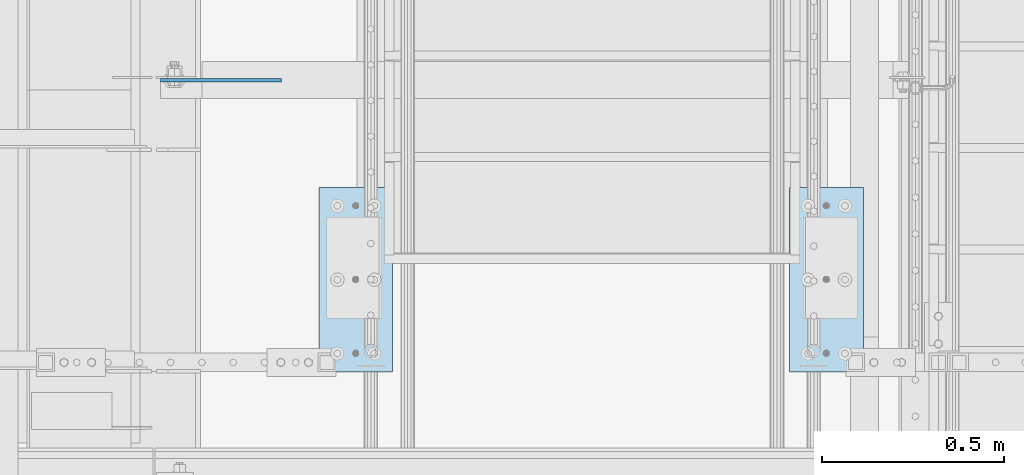
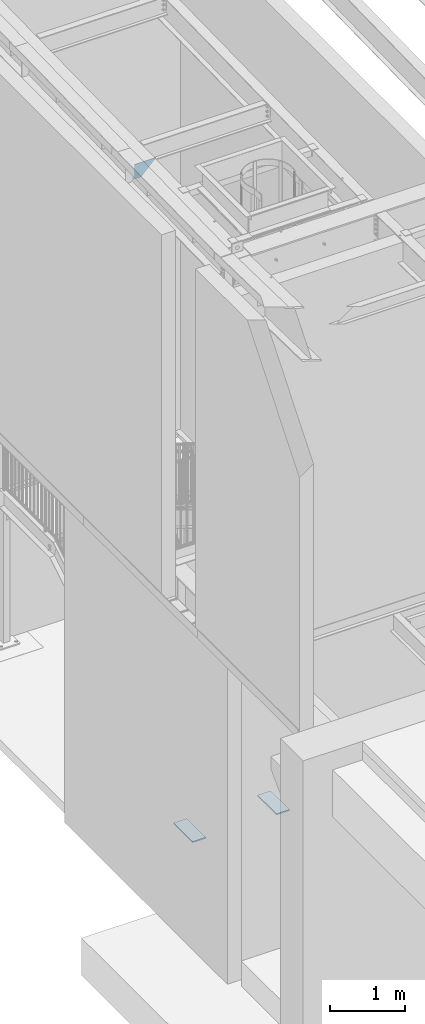
# One storey, part 1509 of 1763: 3 plates, 3 elements without a shape of their own.
"""IFC2X3 building model written with IfcOpenShell, lengths in millimetres."""

import ifcopenshell
import ifcopenshell.guid

model = None  # the IFC model being written
_history = None  # IfcOwnerHistory: only IFC2X3 demands one
_inside = {}  # id of a spatial element -> (the spatial element, [elements in it])
_under = {}  # id of a project, library or spatial element -> (it, [spatial elements below it])
_declared = {}  # id of a project -> (the project, [libraries it declares])
_typed = {}  # id of a type object -> (the type object, [elements of that type])
_made_of = {}  # id of a material, layer set ... -> (it, [elements and type objects made of it])


def new_model(schema):
    """Start an empty IFC model of exactly this schema.

    Asked for "IFC4X3", IfcOpenShell would pick the latest addendum, in which some entities
    have other attributes; the version numbers below select the first issue.
    IFC2X3 requires an IfcOwnerHistory on every rooted entity: one is made here for all.
    """
    global model, _history
    if schema == "IFC4X3":
        model = ifcopenshell.file(schema_version=(4, 3, 0, 0))
    else:
        model = ifcopenshell.file(schema=schema)
    _inside.clear()
    _under.clear()
    _declared.clear()
    _typed.clear()
    _made_of.clear()
    _history = None
    if model.schema == "IFC2X3":
        org = make("IfcOrganization", Name="unknown")
        user = make(
            "IfcPersonAndOrganization",
            ThePerson=make("IfcPerson", FamilyName="unknown"),
            TheOrganization=org,
        )
        app = make(
            "IfcApplication",
            ApplicationDeveloper=org,
            Version="unknown",
            ApplicationFullName="unknown",
            ApplicationIdentifier="unknown",
        )
        _history = make(
            "IfcOwnerHistory",
            OwningUser=user,
            OwningApplication=app,
            ChangeAction="ADDED",
            CreationDate=0,
        )
    return model


def make(cls, **values):
    """One entity of the class cls with the attributes given. An attribute that is None is left unset."""
    return model.create_entity(
        cls, **{name: value for name, value in values.items() if value is not None}
    )


def rooted(cls, **values):
    """An entity with a GlobalId (a new one), such as an element, a storey or a relation."""
    return make(cls, GlobalId=ifcopenshell.guid.new(), OwnerHistory=_history, **values)


def si_unit(unit_type, name, prefix=None):
    """IfcSIUnit, for example si_unit("LENGTHUNIT", "METRE", prefix="MILLI")."""
    return make("IfcSIUnit", UnitType=unit_type, Prefix=prefix, Name=name)


def assignment(units):
    """IfcUnitAssignment: the units of a project."""
    return None if units is None else make("IfcUnitAssignment", Units=units)


def point(xyz):
    """IfcCartesianPoint."""
    return None if xyz is None else make("IfcCartesianPoint", Coordinates=xyz)


def direction(xyz):
    """IfcDirection."""
    return None if xyz is None else make("IfcDirection", DirectionRatios=xyz)


def frame(location, z_axis=None, x_axis=None):
    """IfcAxis2Placement3D, a coordinate frame: its origin and axes. An axis left out is left unset."""
    return make(
        "IfcAxis2Placement3D",
        Location=point(location),
        Axis=direction(z_axis),
        RefDirection=direction(x_axis),
    )


def origin_with_axes():
    """The frame at (0, 0, 0) with the z axis (0, 0, 1) and the x axis (1, 0, 0) written out."""
    return frame((0.0, 0.0, 0.0), z_axis=(0.0, 0.0, 1.0), x_axis=(1.0, 0.0, 0.0))


def place(relative_to, where):
    """IfcLocalPlacement: puts the frame where relative to a parent placement (None: the world)."""
    return make(
        "IfcLocalPlacement", PlacementRelTo=relative_to, RelativePlacement=where
    )


def context(
    kind, dimensions, precision=None, world=None, true_north=None, identifier=None
):
    """IfcGeometricRepresentationContext, for example the 3D "Model" context."""
    return make(
        "IfcGeometricRepresentationContext",
        ContextIdentifier=identifier,
        ContextType=kind,
        CoordinateSpaceDimension=dimensions,
        Precision=precision,
        WorldCoordinateSystem=world,
        TrueNorth=true_north,
    )


def subcontext(parent, identifier, kind, view, scale=None):
    """IfcGeometricRepresentationSubContext, for example "Body" below "Model"."""
    return make(
        "IfcGeometricRepresentationSubContext",
        ContextIdentifier=identifier,
        ContextType=kind,
        ParentContext=parent,
        TargetScale=scale,
        TargetView=view,
    )


def project(units=None, contexts=None):
    """IfcProject with its units and contexts."""
    return rooted(
        "IfcProject",
        Name="project",
        RepresentationContexts=contexts,
        UnitsInContext=assignment(units),
    )


def spatial(cls, under=None, at=None, **own):
    """A site, building, storey or space (cls), placed at a placement, below another one or the project."""
    s = rooted(cls, ObjectPlacement=at, **own)
    if under is not None:
        _under.setdefault(under.id(), (under, []))[1].append(s)
    return s


def faces_of(points, faces, orient=None, outer=None):
    """IfcFace entities. A face is a list of loops; a loop is a list of indices into points, from 0.

    orient and outer hold one flag for each loop. By default every Orientation is true, the
    first loop of a face is its IfcFaceOuterBound and the others are IfcFaceBound.
    """
    made = []
    for i, loops in enumerate(faces):
        bounds = []
        for j, loop in enumerate(loops):
            is_outer = j == 0 if outer is None else outer[i][j]
            bounds.append(
                make(
                    "IfcFaceOuterBound" if is_outer else "IfcFaceBound",
                    Bound=make("IfcPolyLoop", Polygon=[points[k] for k in loop]),
                    Orientation=True if orient is None else orient[i][j],
                )
            )
        made.append(make("IfcFace", Bounds=bounds))
    return made


def faceted_brep(points, faces, orient=None, outer=None, voids=None):
    """IfcFacetedBrep: a solid bounded by flat faces; with voids (closed shells), ...WithVoids."""
    shared = [point(p) for p in points]
    hull = make("IfcClosedShell", CfsFaces=faces_of(shared, faces, orient, outer))
    if voids is None:
        return make("IfcFacetedBrep", Outer=hull)
    return make(
        "IfcFacetedBrepWithVoids",
        Outer=hull,
        Voids=[
            make(cls, CfsFaces=faces_of(shared, fs, o, b)) for cls, fs, o, b in voids
        ],
    )


def shape(context_of_items, identifier, shape_type, items):
    """IfcShapeRepresentation: the items that make up one representation, for example the "Body"."""
    return make(
        "IfcShapeRepresentation",
        ContextOfItems=context_of_items,
        RepresentationIdentifier=identifier,
        RepresentationType=shape_type,
        Items=items,
    )


def material(Name=None, Category=None):
    """IfcMaterial."""
    return make("IfcMaterial", Name=Name, Category=Category)


def made_of(thing, what):
    """Note that an element or type object is made of a material, layer set ...; save() writes the relation."""
    if what is not None:
        _made_of.setdefault(what.id(), (what, []))[1].append(thing)
    return thing


def type_object(cls, material=None, **own):
    """A type object (cls), such as IfcWallType, which elements share."""
    return made_of(rooted(cls, **own), material)


def element(
    cls,
    number,
    at=None,
    inside=None,
    cuts=None,
    type_object=None,
    material=None,
    context=None,
    identifier="Body",
    shape_type=None,
    held_by="IfcProductDefinitionShape",
    body=None,
    shapes=None,
    **own,
):
    """One element of the class cls, such as IfcWall. Its Tag is "e" and its number.

    at: its placement. inside: the storey or other place that contains it. cuts: it is an
    opening in that element (IfcRelVoidsElement). A single representation is given by context,
    identifier, shape_type and body (its items); several are given by shapes. held_by: the class
    of the entity that holds the representations. save() writes the other relations.
    """
    e = rooted(cls, Tag="e%d" % number, ObjectPlacement=at, **own)
    if body is not None:
        shapes = [shape(context, identifier, shape_type, body)]
    if shapes is not None:
        e.Representation = make(held_by, Representations=shapes)
    if inside is not None:
        _inside.setdefault(inside.id(), (inside, []))[1].append(e)
    if cuts is not None:
        rooted(
            "IfcRelVoidsElement", RelatingBuildingElement=cuts, RelatedOpeningElement=e
        )
    if type_object is not None:
        _typed.setdefault(type_object.id(), (type_object, []))[1].append(e)
    return made_of(e, material)


def aggregate(whole, parts):
    """IfcRelAggregates: a whole, such as a stair, and the parts it consists of."""
    return rooted("IfcRelAggregates", RelatingObject=whole, RelatedObjects=parts)


def save(model, path):
    """Write the relations noted so far, then the file.

    IfcRelAggregates (storeys below a building ...), IfcRelContainedInSpatialStructure (elements
    in a storey), IfcRelDefinesByType, IfcRelAssociatesMaterial and IfcRelDeclares: one each for
    every whole, place, type object, material and project.
    """
    for whole, parts in _under.values():
        aggregate(whole, parts)
    for where, things in _inside.values():
        rooted(
            "IfcRelContainedInSpatialStructure",
            RelatedElements=things,
            RelatingStructure=where,
        )
    for kind, things in _typed.values():
        rooted("IfcRelDefinesByType", RelatedObjects=things, RelatingType=kind)
    for what, things in _made_of.values():
        rooted("IfcRelAssociatesMaterial", RelatedObjects=things, RelatingMaterial=what)
    for by, libraries in _declared.values():
        rooted("IfcRelDeclares", RelatingContext=by, RelatedDefinitions=libraries)
    model.write(path)


model = new_model("IFC2X3")

# Units and contexts
model_context = context("Model", 3, precision=1e-05, world=origin_with_axes())
body_context = subcontext(model_context, "Body", "Model", "MODEL_VIEW")
ifc_project = project(units=[si_unit("LENGTHUNIT", "METRE", prefix="MILLI"), si_unit("AREAUNIT", "SQUARE_METRE"), si_unit("VOLUMEUNIT", "CUBIC_METRE"), si_unit("MASSUNIT", "GRAM", prefix="KILO"), si_unit("TIMEUNIT", "SECOND"), si_unit("PLANEANGLEUNIT", "RADIAN"), si_unit("SOLIDANGLEUNIT", "STERADIAN"), si_unit("THERMODYNAMICTEMPERATUREUNIT", "DEGREE_CELSIUS"), si_unit("LUMINOUSINTENSITYUNIT", "LUMEN")], contexts=[model_context])

# Site, building, storey
site_placement = place(None, origin_with_axes())
site = spatial("IfcSite", under=ifc_project, at=site_placement, CompositionType="ELEMENT")
building_placement = place(site_placement, origin_with_axes())
building = spatial("IfcBuilding", under=site, at=building_placement, Name="Undefined", CompositionType="ELEMENT")
storey_placement = place(building_placement, origin_with_axes())
storey = spatial("IfcBuildingStorey", under=building, at=storey_placement, Name="Undefined", CompositionType="ELEMENT", Elevation=0.0)

# Assembly, plate
assembly_1_placement = place(storey_placement, origin_with_axes())
assembly_1 = element("IfcElementAssembly", 1, at=assembly_1_placement, inside=storey, Name="PLATE", AssemblyPlace="NOTDEFINED", PredefinedType="RIGID_FRAME")
ifc_material = material(Name="STEEL/A36")
plate_type_1 = type_object("IfcPlateType", PredefinedType="NOTDEFINED")
plate_1_placement = place(assembly_1_placement, frame((-85422.8122767855, 32504.7777095314, 295.274960436505), z_axis=(-1.0, 0.0, 0.0), x_axis=(0.0, -1.0, 0.0)))
plate_1 = element("IfcPlate", 2, at=plate_1_placement, type_object=plate_type_1, material=ifc_material, Name="PLATE", context=body_context, shape_type="Brep", body=[
    faceted_brep([(0.0, -9.52500000000146, 0.0), (3.63797880709171e-12, -9.52499999999998, 203.199996948242), (3.63797880709171e-12, 9.52499999999998, 203.199996948242), (0.0, 9.52500000000146, 0.0), (508.0, -9.52499999999998, 203.199996948242), (508.0, 9.52499999999998, 203.199996948242), (508.0, -9.52499999999998, 0.0), (508.0, 9.52499999999998, 0.0)], [[[0, 1, 2, 3]], [[1, 4, 5, 2]], [[4, 6, 7, 5]], [[6, 0, 3, 7]], [[5, 7, 3, 2]], [[6, 4, 1, 0]]]),
])
aggregate(assembly_1, [plate_1])

assembly_2_placement = place(storey_placement, origin_with_axes())
assembly_2 = element("IfcElementAssembly", 3, at=assembly_2_placement, inside=storey, Name="PLATE", AssemblyPlace="NOTDEFINED", PredefinedType="RIGID_FRAME")
plate_2_placement = place(assembly_2_placement, frame((-86921.4122706705, 32504.7777095314, 295.275030132566), z_axis=(1.0, 0.0, 0.0), x_axis=(0.0, -1.0, 0.0)))
plate_2 = element("IfcPlate", 4, at=plate_2_placement, type_object=plate_type_1, material=ifc_material, Name="PLATE", context=body_context, shape_type="Brep", body=[
    faceted_brep([(0.0, -9.52500000000146, 0.0), (3.63797880709171e-12, -9.52499999999998, 203.199996948242), (3.63797880709171e-12, 9.52499999999998, 203.199996948242), (0.0, 9.52500000000146, 0.0), (508.0, -9.52499999999998, 203.199996948242), (508.0, 9.52499999999998, 203.199996948242), (508.0, -9.52499999999998, 0.0), (508.0, 9.52499999999998, 0.0)], [[[0, 1, 2, 3]], [[1, 4, 5, 2]], [[4, 6, 7, 5]], [[6, 0, 3, 7]], [[5, 7, 3, 2]], [[6, 4, 1, 0]]]),
])
aggregate(assembly_2, [plate_2])

assembly_3_placement = place(storey_placement, origin_with_axes())
assembly_3 = element("IfcElementAssembly", 5, at=assembly_3_placement, inside=storey, Name="BEAM", AssemblyPlace="NOTDEFINED", PredefinedType="RIGID_FRAME")
plate_type_2 = type_object("IfcPlateType", PredefinedType="NOTDEFINED")
plate_3_placement = place(assembly_3_placement, frame((-87260.0435256352, 32799.3375080762, 10800.4948183331), z_axis=(-0.707106781186552, 0.0, 0.707106781186543), x_axis=(0.707106781186542, 0.0, 0.707106781186553)))
plate_3 = element("IfcPlate", 6, at=plate_3_placement, type_object=plate_type_2, material=ifc_material, Name="PLATE", context=body_context, shape_type="Brep", body=[
    faceted_brep([(0.0, -4.76249999999982, 0.0), (-68.6865768438074, -4.76249999999709, 68.6865844732238), (-68.6865768438074, 4.76249999999709, 68.6865844732238), (0.0, 4.76249999999982, 0.0), (98.2851104731089, -4.76249999999709, 235.658279419542), (98.2851104731089, 4.76249999999709, 235.658279419542), (333.943389893917, -4.76249999999709, -3.92901711165905e-10), (333.943389893917, 4.76249999999709, -3.92901711165905e-10)], [[[0, 1, 2, 3]], [[1, 4, 5, 2]], [[4, 6, 7, 5]], [[6, 0, 3, 7]], [[5, 7, 3, 2]], [[6, 4, 1, 0]]]),
])
aggregate(assembly_3, [plate_3])

save(model, "model.ifc")
